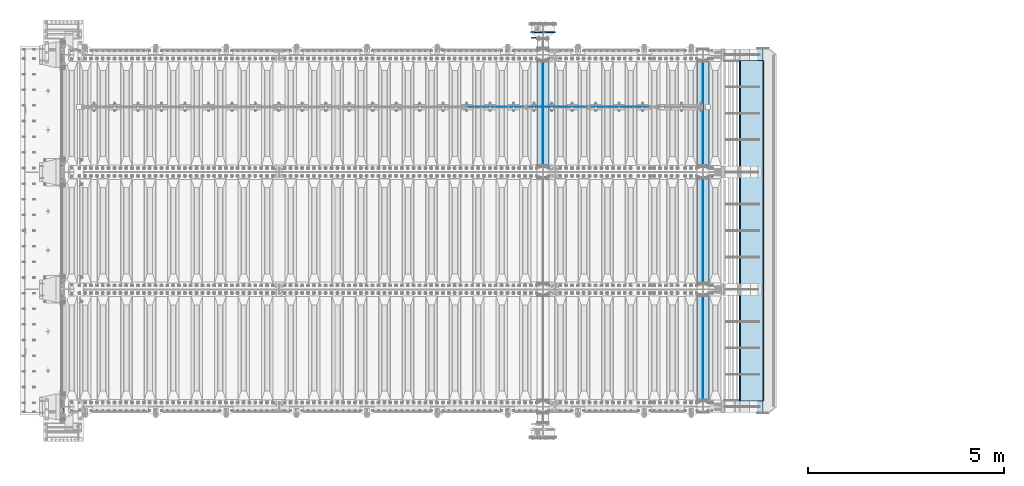
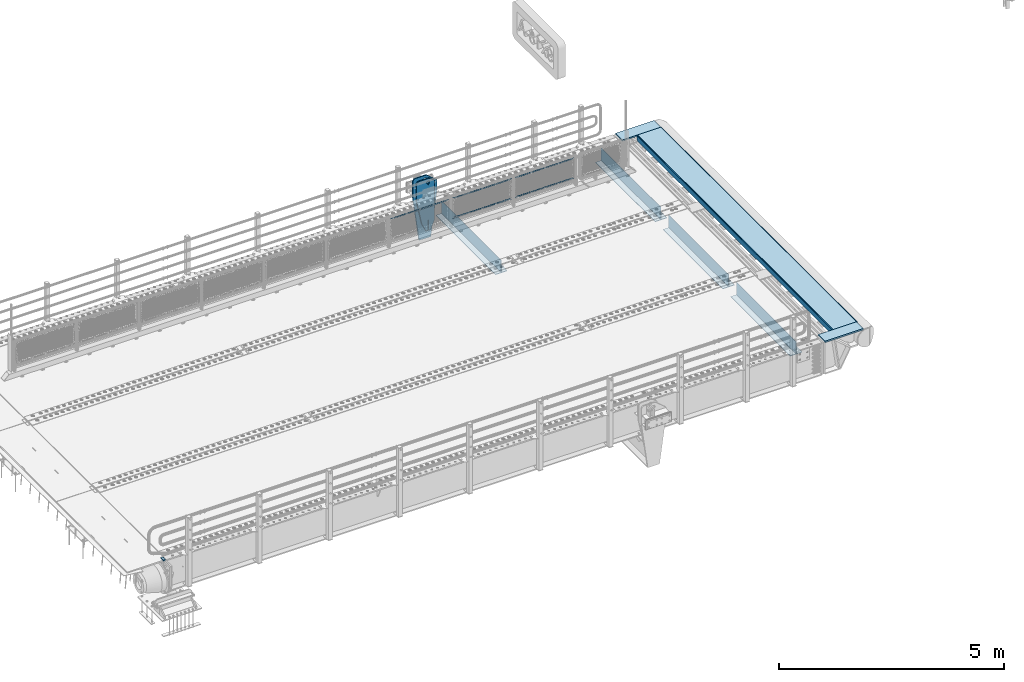
# One storey, part 195 of 247: 20 plates.
"""IFC2X3 building model written with IfcOpenShell, lengths in millimetres."""

import ifcopenshell
import ifcopenshell.guid

model = None  # the IFC model being written
_history = None  # IfcOwnerHistory: only IFC2X3 demands one
_inside = {}  # id of a spatial element -> (the spatial element, [elements in it])
_under = {}  # id of a project, library or spatial element -> (it, [spatial elements below it])
_declared = {}  # id of a project -> (the project, [libraries it declares])
_typed = {}  # id of a type object -> (the type object, [elements of that type])
_made_of = {}  # id of a material, layer set ... -> (it, [elements and type objects made of it])


def new_model(schema):
    """Start an empty IFC model of exactly this schema.

    Asked for "IFC4X3", IfcOpenShell would pick the latest addendum, in which some entities
    have other attributes; the version numbers below select the first issue.
    IFC2X3 requires an IfcOwnerHistory on every rooted entity: one is made here for all.
    """
    global model, _history
    if schema == "IFC4X3":
        model = ifcopenshell.file(schema_version=(4, 3, 0, 0))
    else:
        model = ifcopenshell.file(schema=schema)
    _inside.clear()
    _under.clear()
    _declared.clear()
    _typed.clear()
    _made_of.clear()
    _history = None
    if model.schema == "IFC2X3":
        org = make("IfcOrganization", Name="unknown")
        user = make(
            "IfcPersonAndOrganization",
            ThePerson=make("IfcPerson", FamilyName="unknown"),
            TheOrganization=org,
        )
        app = make(
            "IfcApplication",
            ApplicationDeveloper=org,
            Version="unknown",
            ApplicationFullName="unknown",
            ApplicationIdentifier="unknown",
        )
        _history = make(
            "IfcOwnerHistory",
            OwningUser=user,
            OwningApplication=app,
            ChangeAction="ADDED",
            CreationDate=0,
        )
    return model


def make(cls, **values):
    """One entity of the class cls with the attributes given. An attribute that is None is left unset."""
    return model.create_entity(
        cls, **{name: value for name, value in values.items() if value is not None}
    )


def rooted(cls, **values):
    """An entity with a GlobalId (a new one), such as an element, a storey or a relation."""
    return make(cls, GlobalId=ifcopenshell.guid.new(), OwnerHistory=_history, **values)


def si_unit(unit_type, name, prefix=None):
    """IfcSIUnit, for example si_unit("LENGTHUNIT", "METRE", prefix="MILLI")."""
    return make("IfcSIUnit", UnitType=unit_type, Prefix=prefix, Name=name)


def assignment(units):
    """IfcUnitAssignment: the units of a project."""
    return None if units is None else make("IfcUnitAssignment", Units=units)


def point(xyz):
    """IfcCartesianPoint."""
    return None if xyz is None else make("IfcCartesianPoint", Coordinates=xyz)


def direction(xyz):
    """IfcDirection."""
    return None if xyz is None else make("IfcDirection", DirectionRatios=xyz)


def frame(location, z_axis=None, x_axis=None):
    """IfcAxis2Placement3D, a coordinate frame: its origin and axes. An axis left out is left unset."""
    return make(
        "IfcAxis2Placement3D",
        Location=point(location),
        Axis=direction(z_axis),
        RefDirection=direction(x_axis),
    )


def origin_with_axes():
    """The frame at (0, 0, 0) with the z axis (0, 0, 1) and the x axis (1, 0, 0) written out."""
    return frame((0.0, 0.0, 0.0), z_axis=(0.0, 0.0, 1.0), x_axis=(1.0, 0.0, 0.0))


def place(relative_to, where):
    """IfcLocalPlacement: puts the frame where relative to a parent placement (None: the world)."""
    return make(
        "IfcLocalPlacement", PlacementRelTo=relative_to, RelativePlacement=where
    )


def context(
    kind, dimensions, precision=None, world=None, true_north=None, identifier=None
):
    """IfcGeometricRepresentationContext, for example the 3D "Model" context."""
    return make(
        "IfcGeometricRepresentationContext",
        ContextIdentifier=identifier,
        ContextType=kind,
        CoordinateSpaceDimension=dimensions,
        Precision=precision,
        WorldCoordinateSystem=world,
        TrueNorth=true_north,
    )


def subcontext(parent, identifier, kind, view, scale=None):
    """IfcGeometricRepresentationSubContext, for example "Body" below "Model"."""
    return make(
        "IfcGeometricRepresentationSubContext",
        ContextIdentifier=identifier,
        ContextType=kind,
        ParentContext=parent,
        TargetScale=scale,
        TargetView=view,
    )


def project(units=None, contexts=None):
    """IfcProject with its units and contexts."""
    return rooted(
        "IfcProject",
        Name="project",
        RepresentationContexts=contexts,
        UnitsInContext=assignment(units),
    )


def spatial(cls, under=None, at=None, **own):
    """A site, building, storey or space (cls), placed at a placement, below another one or the project."""
    s = rooted(cls, ObjectPlacement=at, **own)
    if under is not None:
        _under.setdefault(under.id(), (under, []))[1].append(s)
    return s


def faces_of(points, faces, orient=None, outer=None):
    """IfcFace entities. A face is a list of loops; a loop is a list of indices into points, from 0.

    orient and outer hold one flag for each loop. By default every Orientation is true, the
    first loop of a face is its IfcFaceOuterBound and the others are IfcFaceBound.
    """
    made = []
    for i, loops in enumerate(faces):
        bounds = []
        for j, loop in enumerate(loops):
            is_outer = j == 0 if outer is None else outer[i][j]
            bounds.append(
                make(
                    "IfcFaceOuterBound" if is_outer else "IfcFaceBound",
                    Bound=make("IfcPolyLoop", Polygon=[points[k] for k in loop]),
                    Orientation=True if orient is None else orient[i][j],
                )
            )
        made.append(make("IfcFace", Bounds=bounds))
    return made


def faceted_brep(points, faces, orient=None, outer=None, voids=None):
    """IfcFacetedBrep: a solid bounded by flat faces; with voids (closed shells), ...WithVoids."""
    shared = [point(p) for p in points]
    hull = make("IfcClosedShell", CfsFaces=faces_of(shared, faces, orient, outer))
    if voids is None:
        return make("IfcFacetedBrep", Outer=hull)
    return make(
        "IfcFacetedBrepWithVoids",
        Outer=hull,
        Voids=[
            make(cls, CfsFaces=faces_of(shared, fs, o, b)) for cls, fs, o, b in voids
        ],
    )


def shape(context_of_items, identifier, shape_type, items):
    """IfcShapeRepresentation: the items that make up one representation, for example the "Body"."""
    return make(
        "IfcShapeRepresentation",
        ContextOfItems=context_of_items,
        RepresentationIdentifier=identifier,
        RepresentationType=shape_type,
        Items=items,
    )


def material(Name=None, Category=None):
    """IfcMaterial."""
    return make("IfcMaterial", Name=Name, Category=Category)


def made_of(thing, what):
    """Note that an element or type object is made of a material, layer set ...; save() writes the relation."""
    if what is not None:
        _made_of.setdefault(what.id(), (what, []))[1].append(thing)
    return thing


def type_object(cls, material=None, **own):
    """A type object (cls), such as IfcWallType, which elements share."""
    return made_of(rooted(cls, **own), material)


def element(
    cls,
    number,
    at=None,
    inside=None,
    cuts=None,
    type_object=None,
    material=None,
    context=None,
    identifier="Body",
    shape_type=None,
    held_by="IfcProductDefinitionShape",
    body=None,
    shapes=None,
    **own,
):
    """One element of the class cls, such as IfcWall. Its Tag is "e" and its number.

    at: its placement. inside: the storey or other place that contains it. cuts: it is an
    opening in that element (IfcRelVoidsElement). A single representation is given by context,
    identifier, shape_type and body (its items); several are given by shapes. held_by: the class
    of the entity that holds the representations. save() writes the other relations.
    """
    e = rooted(cls, Tag="e%d" % number, ObjectPlacement=at, **own)
    if body is not None:
        shapes = [shape(context, identifier, shape_type, body)]
    if shapes is not None:
        e.Representation = make(held_by, Representations=shapes)
    if inside is not None:
        _inside.setdefault(inside.id(), (inside, []))[1].append(e)
    if cuts is not None:
        rooted(
            "IfcRelVoidsElement", RelatingBuildingElement=cuts, RelatedOpeningElement=e
        )
    if type_object is not None:
        _typed.setdefault(type_object.id(), (type_object, []))[1].append(e)
    return made_of(e, material)


def aggregate(whole, parts):
    """IfcRelAggregates: a whole, such as a stair, and the parts it consists of."""
    return rooted("IfcRelAggregates", RelatingObject=whole, RelatedObjects=parts)


def save(model, path):
    """Write the relations noted so far, then the file.

    IfcRelAggregates (storeys below a building ...), IfcRelContainedInSpatialStructure (elements
    in a storey), IfcRelDefinesByType, IfcRelAssociatesMaterial and IfcRelDeclares: one each for
    every whole, place, type object, material and project.
    """
    for whole, parts in _under.values():
        aggregate(whole, parts)
    for where, things in _inside.values():
        rooted(
            "IfcRelContainedInSpatialStructure",
            RelatedElements=things,
            RelatingStructure=where,
        )
    for kind, things in _typed.values():
        rooted("IfcRelDefinesByType", RelatedObjects=things, RelatingType=kind)
    for what, things in _made_of.values():
        rooted("IfcRelAssociatesMaterial", RelatedObjects=things, RelatingMaterial=what)
    for by, libraries in _declared.values():
        rooted("IfcRelDeclares", RelatingContext=by, RelatedDefinitions=libraries)
    model.write(path)


model = new_model("IFC2X3")

# Units and contexts
model_context = context("Model", 3, precision=1e-05, world=origin_with_axes())
body_context = subcontext(model_context, "Body", "Model", "MODEL_VIEW")
ifc_project = project(units=[si_unit("LENGTHUNIT", "METRE", prefix="MILLI"), si_unit("AREAUNIT", "SQUARE_METRE"), si_unit("VOLUMEUNIT", "CUBIC_METRE"), si_unit("MASSUNIT", "GRAM", prefix="KILO"), si_unit("TIMEUNIT", "SECOND"), si_unit("PLANEANGLEUNIT", "RADIAN"), si_unit("SOLIDANGLEUNIT", "STERADIAN"), si_unit("THERMODYNAMICTEMPERATUREUNIT", "DEGREE_CELSIUS"), si_unit("LUMINOUSINTENSITYUNIT", "LUMEN")], contexts=[model_context])

# Site, building, storey
site_placement = place(None, origin_with_axes())
site = spatial("IfcSite", under=ifc_project, at=site_placement, CompositionType="ELEMENT")
building_placement = place(site_placement, origin_with_axes())
building = spatial("IfcBuilding", under=site, at=building_placement, Name="Standard", CompositionType="ELEMENT")
storey_placement = place(building_placement, origin_with_axes())
storey = spatial("IfcBuildingStorey", under=building, at=storey_placement, Name="Undefined", CompositionType="ELEMENT", Elevation=0.0)

# Plates
ifc_material_1 = material()
plate_type_1 = type_object("IfcPlateType", PredefinedType="NOTDEFINED")
plate_1_placement = place(storey_placement, frame((-10.0000000600431, -89.9999995680746, -15.999780610769), z_axis=(-1.0, 0.0, 0.0), x_axis=(0.0, -4.95099999998473e-06, 0.999999999987744)))
element("IfcPlate", 1, at=plate_1_placement, inside=storey, type_object=plate_type_1, material=ifc_material_1, context=body_context, shape_type="Brep", body=[
    faceted_brep([(0.0, -59.9999999999991, 0.0), (-0.000933120085690575, -60.0, 60.0), (-0.000933120085690575, 60.0, 60.0), (-3.5527136788005e-15, 60.0000000000005, 0.0), (24.9991450303709, -60.0, 60.0), (24.9991450303709, 60.0, 60.0), (26.544215218168, -60.0, 59.7552873850884), (26.544215218168, 60.0, 59.7552873850884), (27.9380461396139, -60.0, 59.0451032459123), (27.9380461396139, 60.0, 59.0451032459123), (29.0442025908961, -60.0, 57.9389639895784), (29.0442025908961, 60.0, 57.9389639895784), (29.7544083969366, -60.0, 56.5451441080361), (29.7544083969366, 60.0, 56.5451441080361), (29.9991450297669, -60.0, 55.0000777244568), (29.9991450297668, 60.0, 55.0000777244568), (29.999922274335, -60.0, 5.00007772445704), (29.999922274335, 60.0, 5.00007772445704), (29.7552240705896, -60.0, 3.45497416452589), (29.7552240705896, 60.0, 3.45497416452589), (29.0450346578116, -60.0, 2.0611114669096), (29.0450346578116, 60.0, 2.06111146690959), (27.9388736885072, -60.0, 0.954933302319514), (27.9388736885072, 60.0, 0.954933302319514), (26.5450220308766, -60.0, 0.244722222183091), (26.5450220308766, 60.0, 0.244722222183089), (24.9999222749392, -60.0, 2.66453525910038e-13), (24.9999222749392, 60.0, 2.66453525910038e-13)], [[[0, 1, 2, 3]], [[1, 4, 5, 2]], [[4, 6, 7, 5]], [[6, 8, 9, 7]], [[8, 10, 11, 9]], [[10, 12, 13, 11]], [[12, 14, 15, 13]], [[14, 16, 17, 15]], [[16, 18, 19, 17]], [[18, 20, 21, 19]], [[20, 22, 23, 21]], [[22, 24, 25, 23]], [[24, 26, 27, 25]], [[26, 0, 3, 27]], [[5, 7, 9, 11, 13, 15, 17, 19, 21, 23, 25, 27, 3, 2]], [[26, 24, 22, 20, 18, 16, 14, 12, 10, 8, 6, 4, 1, 0]]]),
])
ifc_material_2 = material(Name="STEEL/S355N")
plate_type_2 = type_object("IfcPlateType", PredefinedType="NOTDEFINED")
for number, where, z_axis, x_axis in (
    (2, (16195.0, 175.0, -343.0), (0.0, 1.0, 0.0), (1.0, 0.0, 0.0)),
    (3, (16195.0, 3175.0, -343.0), (0.0, 1.0, 0.0), (1.0, 0.0, 0.0)),
    (4, (16195.0, 6175.0, -343.0), (0.0, 1.0, 0.0), (1.0, 0.0, 0.0)),
    (5, (12100.0, 6175.0, -343.0), (0.0, 1.0, 0.0), (1.0, 0.0, 0.0)),
):
    element("IfcPlate", number, at=place(storey_placement, frame(where, z_axis=z_axis, x_axis=x_axis)), inside=storey, type_object=plate_type_2, material=ifc_material_2, context=body_context, shape_type="Brep", body=[
        faceted_brep([(0.0, -7.0, 0.0), (0.0, -7.0, 2650.0), (0.0, 7.0, 2650.0), (0.0, 7.0, 0.0), (300.0, -7.0, 2650.0), (300.0, 7.0, 2650.0), (300.0, -7.0, 0.0), (300.0, 7.0, 0.0)], [[[0, 1, 2, 3]], [[1, 4, 5, 2]], [[4, 6, 7, 5]], [[6, 0, 3, 7]], [[5, 7, 3, 2]], [[6, 4, 1, 0]]]),
    ])
plate_type_3 = type_object("IfcPlateType", PredefinedType="NOTDEFINED")
for number, where, z_axis, x_axis in (
    (6, (16345.0, 2825.0, 0.0), (0.0, 0.0, -1.0), (0.0, -0.999999999999548, -9.5100000000016e-07)),
    (7, (16345.0, 5825.0, 0.0), (0.0, 0.0, -1.0), (0.0, -0.999999999999548, -9.5100000000016e-07)),
    (8, (16345.0, 8825.0, 0.0), (0.0, 0.0, -1.0), (0.0, -0.999999999999548, -9.5100000000016e-07)),
    (9, (12250.0, 8825.0, 0.0), (0.0, 0.0, -1.0), (0.0, -0.999999999999548, -9.5100000000016e-07)),
):
    element("IfcPlate", number, at=place(storey_placement, frame(where, z_axis=z_axis, x_axis=x_axis)), inside=storey, type_object=plate_type_3, material=ifc_material_2, context=body_context, shape_type="Brep", body=[
        faceted_brep([(9.04219632502645e-09, -5.00000000143385, -2.89173840428703e-09), (0.0, -5.0, 336.0), (0.0, 5.0, 336.0), (7.66340235713869e-09, 4.99999999856618, -2.89173840428703e-09), (2650.0, -5.0, 336.0), (2650.0, 5.0, 336.0), (2650.0, -5.0, 0.0), (2650.0, 5.0, 0.0)], [[[0, 1, 2, 3]], [[1, 4, 5, 2]], [[4, 6, 7, 5]], [[6, 0, 3, 7]], [[5, 7, 3, 2]], [[6, 4, 1, 0]]]),
    ])
ifc_material_3 = material(Name="Misc_Undefined")
plate_type_4 = type_object("IfcPlateType", PredefinedType="NOTDEFINED")
plate_2_placement = place(storey_placement, frame((13474.5050117304, 7670.5, 351.520303374641), z_axis=(0.0, 0.0, 1.0), x_axis=(1.0, 0.0, 0.0)))
element("IfcPlate", 10, at=plate_2_placement, inside=storey, type_object=plate_type_4, material=ifc_material_3, context=body_context, shape_type="Brep", body=[
    faceted_brep([(1.81898940354586e-12, -1.5, -5.6843418860808e-14), (35.0002975463885, -1.5, 34.9996948242187), (35.0002975463885, 1.5, 34.9996948242187), (1.81898940354586e-12, 1.5, -5.6843418860808e-14), (1457.99035644531, -1.5, 34.9999923706055), (1457.99035644531, 1.5, 34.9999923706055), (1492.98999023438, -1.5, -2.87985812974512e-09), (1492.98999023438, 1.5, -2.87985812974512e-09)], [[[0, 1, 2, 3]], [[1, 4, 5, 2]], [[4, 6, 7, 5]], [[6, 0, 3, 7]], [[5, 7, 3, 2]], [[6, 4, 1, 0]]]),
])
plate_3_placement = place(storey_placement, frame((14967.5000001876, 7670.5, 914.520000175701), z_axis=(-0.707103624179499, 0.0, 0.707109938179501), x_axis=(-0.707109938179502, 0.0, -0.707103624179498)))
element("IfcPlate", 11, at=plate_3_placement, inside=storey, type_object=plate_type_4, material=ifc_material_3, context=body_context, shape_type="Brep", body=[
    faceted_brep([(1.81898940354586e-12, -1.5, -5.6843418860808e-14), (1055.71520996094, -1.5, 1055.70581054688), (1055.71520996094, 1.5, 1055.70581054688), (1.81898940354586e-12, 1.5, -5.6843418860808e-14), (1055.70812988281, -1.5, 1006.20135498047), (1055.70812988281, 1.5, 1006.20135498047), (49.4976959228497, -1.5, 7.09405867382884e-11), (49.4976959228497, 1.5, 7.09405867382884e-11)], [[[0, 1, 2, 3]], [[1, 4, 5, 2]], [[4, 6, 7, 5]], [[6, 0, 3, 7]], [[5, 7, 3, 2]], [[6, 4, 1, 0]]]),
])
plate_4_placement = place(storey_placement, frame((11874.5050117304, 7670.5, 351.520303374641), z_axis=(0.0, 0.0, 1.0), x_axis=(1.0, 0.0, 0.0)))
element("IfcPlate", 12, at=plate_4_placement, inside=storey, type_object=plate_type_4, material=ifc_material_3, context=body_context, shape_type="Brep", body=[
    faceted_brep([(1.81898940354586e-12, -1.5, -5.6843418860808e-14), (35.0002975463885, -1.5, 34.9996948242187), (35.0002975463885, 1.5, 34.9996948242187), (1.81898940354586e-12, 1.5, -5.6843418860808e-14), (1457.99035644531, -1.5, 34.9999923706055), (1457.99035644531, 1.5, 34.9999923706055), (1492.98999023438, -1.5, -2.87985812974512e-09), (1492.98999023438, 1.5, -2.87985812974512e-09)], [[[0, 1, 2, 3]], [[1, 4, 5, 2]], [[4, 6, 7, 5]], [[6, 0, 3, 7]], [[5, 7, 3, 2]], [[6, 4, 1, 0]]]),
])
for number, where, z_axis, x_axis in (
    (13, (13367.5000001876, 7670.5, 914.520000175701), (-0.707103624179499, 0.0, 0.707109938179501), (-0.707109938179502, 0.0, -0.707103624179498)),
    (14, (11767.5000001876, 7670.5, 914.520000175701), (-0.707103624179499, 0.0, 0.707109938179501), (-0.707109938179502, 0.0, -0.707103624179498)),
):
    element("IfcPlate", number, at=place(storey_placement, frame(where, z_axis=z_axis, x_axis=x_axis)), inside=storey, type_object=plate_type_4, material=ifc_material_3, context=body_context, shape_type="Brep", body=[
        faceted_brep([(1.81898940354586e-12, -1.5, -5.6843418860808e-14), (1055.71520996094, -1.5, 1055.70581054688), (1055.71520996094, 1.5, 1055.70581054688), (1.81898940354586e-12, 1.5, -5.6843418860808e-14), (1055.70812988281, -1.5, 1006.20135498047), (1055.70812988281, 1.5, 1006.20135498047), (49.4976959228497, -1.5, 7.09405867382884e-11), (49.4976959228497, 1.5, 7.09405867382884e-11)], [[[0, 1, 2, 3]], [[1, 4, 5, 2]], [[4, 6, 7, 5]], [[6, 0, 3, 7]], [[5, 7, 3, 2]], [[6, 4, 1, 0]]]),
    ])
plate_type_5 = type_object("IfcPlateType", PredefinedType="NOTDEFINED")
for number, where, z_axis, x_axis in (
    (15, (16896.9988298906, 150.0, -10.0000000000094), (1.0, 0.0, 0.0), (0.0, -0.999999999999548, -9.5100000000016e-07)),
    (16, (16896.9988298905, 9150.0, -10.0000000004865), (1.0, 0.0, 0.0), (0.0, -0.999999999999548, -9.5100000000016e-07)),
):
    element("IfcPlate", number, at=place(storey_placement, frame(where, z_axis=z_axis, x_axis=x_axis)), inside=storey, type_object=plate_type_5, material=ifc_material_2, context=body_context, shape_type="Brep", body=[
        faceted_brep([(300.0, 7.0, 986.0), (300.0, 20.0, 956.0), (-3.35091954184463e-11, 20.0, 956.0), (-3.45607986673713e-11, 7.0, 986.0), (0.0, 20.0, 0.0), (0.0, -20.0, 0.0), (-3.45607986673713e-11, -20.0, 986.0), (300.0, -20.0, 986.0), (300.0, -20.0, -1.81898940354586e-12), (300.0, 20.0, -1.81898940354586e-12)], [[[0, 1, 2, 3]], [[4, 5, 6, 3, 2]], [[6, 7, 0, 3]], [[7, 8, 9, 1, 0]], [[8, 5, 4, 9]], [[9, 4, 2, 1]], [[8, 7, 6, 5]]]),
    ])
plate_type_6 = type_object("IfcPlateType", PredefinedType="NOTDEFINED")
plate_5_placement = place(storey_placement, frame((12409.9999999856, 9440.00000001511, -945.000018222004), z_axis=(-0.901283188008788, 0.0, 0.433230441004225), x_axis=(-0.433230441004223, 0.0, -0.901283188008789)))
element("IfcPlate", 17, at=plate_5_placement, inside=storey, type_object=plate_type_6, material=ifc_material_2, context=body_context, shape_type="Brep", body=[
    faceted_brep([(-929.368911797765, -14.9999999999964, 583.252555031771), (-929.368911797765, 15.0000000000036, 583.252555031771), (-937.308302015212, 15.0000000000036, 596.689503306548), (-937.308302015212, -14.9999999999964, 596.689503306548), (-939.501244651428, 15.0000000000036, 612.141897896323), (-939.501244651428, -14.9999999999964, 612.141897896323), (-935.613884069125, 15.0000000000036, 627.257251801113), (-935.613884069125, -14.9999999999964, 627.257251801113), (-926.238035677946, 15.0000000000036, 639.734389409936), (-926.238035677946, -14.9999999999964, 639.734389409936), (-912.801087403171, 15.0000000000036, 647.673779627383), (-912.801087403171, -14.9999999999964, 647.673779627383), (-897.348692813394, 15.0000000000036, 649.866722263598), (-897.348692813394, -14.9999999999964, 649.866722263598), (-882.233338908604, 15.0000000000036, 645.979361681295), (-882.233338908604, -14.9999999999964, 645.979361681295), (-869.756201299781, 15.0000000000036, 636.603513290116), (-869.756201299781, -14.9999999999964, 636.603513290116), (-861.816811082334, 15.0000000000036, 623.166565015341), (-861.816811082334, -14.9999999999964, 623.166565015341), (-859.623868446118, 15.0000000000036, 607.714170425565), (-859.623868446118, -14.9999999999964, 607.714170425565), (-863.511229028422, 15.0000000000036, 592.598816520775), (-863.511229028422, -14.9999999999964, 592.598816520775), (-872.8870774196, 15.0000000000036, 580.121678911952), (-872.8870774196, -14.9999999999964, 580.121678911952), (-886.324025694375, 15.0000000000036, 572.182288694507), (-886.324025694375, -14.9999999999964, 572.182288694507), (-901.776420284152, 15.0000000000036, 569.98934605829), (-901.776420284152, -14.9999999999964, 569.98934605829), (-916.891774188942, 15.0000000000036, 573.876706640593), (-916.891774188942, -14.9999999999964, 573.876706640593), (264.349945986183, -15.0, 42.1349880418893), (264.349945986183, 15.0, 42.1349880418893), (15.5957837368442, 15.0000000000036, 161.706590892942), (15.5957837368442, -14.9999999999964, 161.706590892942), (244.096420288085, -15.0, -6.73026079311967e-11), (244.096420288085, 15.0, -6.73026079311967e-11), (0.0, -15.0, 0.0), (0.0, 15.0, 0.0), (-976.801696777345, -15.0, 469.530822753904), (-976.801696777345, 15.0, 469.530822753904), (-1005.61097945758, -15.0, 584.572341407271), (-1005.61097945758, 15.0, 584.572341407271), (-1008.62086606962, -15.0, 603.379087420497), (-1008.62086606962, 15.0, 603.379087420497), (-1008.34154488138, -15.0, 622.42311778954), (-1008.34154488138, 15.0, 622.42311778954), (-1004.7813898293, -15.0, 641.133500175492), (-1004.7813898293, 15.0, 641.133500175492), (-998.047132923921, -15.0, 658.949304871174), (-998.047132923921, 15.0, 658.949304871174), (-903.392995239108, -15.0, 855.865677422371), (-903.392995239108, 15.0, 855.865677422371), (-891.965893301475, -15.0, 873.346258360978), (-891.965893301475, 15.0, 873.346258360978), (-876.403853384473, -15.0, 887.273651594), (-876.403853384473, 15.0, 887.273651594), (-857.767402657617, -15.0, 896.698728408073), (-857.767402657617, 15.0, 896.698728408073), (-837.326584280018, -15.0, 900.979185474776), (-837.326584280018, 15.0, 900.979185474776), (-816.474406068869, -15.0, 899.823316755486), (-816.474406068869, 15.0, 899.823316755486), (-796.631909330703, -15.0, 893.309892783485), (-796.631909330703, 15.0, 893.309892783485), (-427.105804443359, -15.0, 715.685424804688), (-427.105804443359, 15.0, 715.685424804688), (138.633743286132, -15.0, 288.41061401367), (138.633743286132, 15.0, 288.41061401367), (291.101928710937, -15.0, 97.7892227172833), (291.101928710937, 15.0, 97.7892227172833), (270.848403398947, -15.0, 55.6542354785815), (270.848403398947, 15.0, 55.6542354785815), (22.0942403519075, -14.9999999999964, 175.225838713073), (22.0942403519075, 15.0000000000036, 175.225838713073), (-855.850321911345, -15.0, 588.916357789718), (-852.143242453128, -15.0, 592.234043561486), (-847.175983322761, -15.0, 591.958700645248), (-843.858297550992, -15.0, 588.25162118703), (-844.133640467231, -15.0, 583.284362056664), (-847.840719925449, -15.0, 579.966676284894), (-852.807979055816, -15.0, 580.242019201134), (-856.125664827585, -15.0, 583.94909865935), (-844.133640467231, 15.0, 583.284362056664), (-847.840719925449, 15.0, 579.966676284894), (-843.858297550992, 15.0, 588.25162118703), (-847.175983322761, 15.0, 591.958700645248), (-852.143242453128, 15.0, 592.234043561486), (-855.850321911345, 15.0, 588.916357789718), (-856.125664827585, 15.0, 583.94909865935), (-852.807979055816, 15.0, 580.242019201134)], [[[0, 1, 2, 3]], [[3, 2, 4, 5]], [[5, 4, 6, 7]], [[7, 6, 8, 9]], [[9, 8, 10, 11]], [[11, 10, 12, 13]], [[13, 12, 14, 15]], [[15, 14, 16, 17]], [[17, 16, 18, 19]], [[19, 18, 20, 21]], [[21, 20, 22, 23]], [[23, 22, 24, 25]], [[25, 24, 26, 27]], [[27, 26, 28, 29]], [[29, 28, 30, 31]], [[31, 30, 1, 0]], [[32, 33, 34, 35]], [[36, 37, 33, 32]], [[36, 38, 39, 37]], [[38, 40, 41, 39]], [[40, 42, 43, 41]], [[42, 44, 45, 43]], [[44, 46, 47, 45]], [[46, 48, 49, 47]], [[48, 50, 51, 49]], [[50, 52, 53, 51]], [[52, 54, 55, 53]], [[54, 56, 57, 55]], [[56, 58, 59, 57]], [[58, 60, 61, 59]], [[60, 62, 63, 61]], [[62, 64, 65, 63]], [[64, 66, 67, 65]], [[66, 68, 69, 67]], [[68, 70, 71, 69]], [[71, 70, 72, 73]], [[74, 75, 73, 72]], [[35, 34, 75, 74]], [[72, 70, 68, 66, 64, 62, 60, 58, 56, 54, 52, 50, 48, 46, 44, 42, 40, 38, 36, 32, 35, 74], [3, 5, 7, 9, 11, 13, 15, 17, 19, 21, 23, 25, 27, 29, 31, 0], [76, 77, 78, 79, 80, 81, 82, 83]], [[80, 84, 85, 81]], [[79, 86, 84, 80]], [[78, 87, 86, 79]], [[77, 88, 87, 78]], [[76, 89, 88, 77]], [[83, 90, 89, 76]], [[82, 91, 90, 83]], [[81, 85, 91, 82]], [[37, 39, 41, 43, 45, 47, 49, 51, 53, 55, 57, 59, 61, 63, 65, 67, 69, 71, 73, 75, 34, 33], [26, 24, 22, 20, 18, 16, 14, 12, 10, 8, 6, 4, 2, 1, 30, 28], [84, 86, 87, 88, 89, 90, 91, 85]]]),
])
plate_type_7 = type_object("IfcPlateType", PredefinedType="NOTDEFINED")
plate_6_placement = place(storey_placement, frame((12399.9999999856, 9580.00000001511, -1470.000018222), z_axis=(0.0, 0.0, 1.0), x_axis=(-1.0, 0.0, 0.0)))
element("IfcPlate", 18, at=plate_6_placement, inside=storey, type_object=plate_type_7, material=ifc_material_2, context=body_context, shape_type="Brep", body=[
    faceted_brep([(145.403805922693, -14.9999999999999, 1549.59619407771), (145.403805922693, 15.0, 1549.59619407771), (150.000000000406, 15.0, 1551.5), (150.000000000406, -14.9999999999999, 1551.5), (154.596194078118, 15.0, 1549.59619407771), (154.596194078118, -14.9999999999999, 1549.59619407771), (156.500000000406, 15.0, 1545.0), (156.500000000406, -14.9999999999999, 1545.0), (154.596194078118, 15.0, 1540.40380592229), (154.596194078118, -14.9999999999999, 1540.40380592229), (150.000000000406, 15.0, 1538.5), (150.000000000406, -14.9999999999999, 1538.5), (145.403805922693, 15.0, 1540.40380592229), (145.403805922693, -14.9999999999999, 1540.40380592229), (143.500000000406, 15.0, 1545.0), (143.500000000406, -14.9999999999999, 1545.0), (300.0, -15.0, 0.0), (0.0, -15.0, 0.0), (0.0, 15.0, 0.0), (300.0, 15.0, 0.0), (462.5, -15.0, 1210.0), (462.5, 15.0, 1210.0), (462.5, -15.0, 1630.0), (462.5, 15.0, 1630.0), (459.774066103126, -15.0, 1650.7055236082), (459.774066103126, 15.0, 1650.7055236082), (451.782032302755, -15.0, 1670.0), (451.782032302755, 15.0, 1670.0), (439.068542494924, -15.0, 1686.56854249492), (439.068542494924, 15.0, 1686.56854249492), (422.5, -15.0, 1699.28203230276), (422.5, 15.0, 1699.28203230276), (403.205523608201, -15.0, 1707.27406610313), (403.205523608201, 15.0, 1707.27406610313), (382.5, -15.0, 1710.0), (382.5, 15.0, 1710.0), (151.788081037079, -15.0, 1710.0), (151.788081037079, 15.0, 1710.0), (132.694887325031, -15.0, 1708.33028179541), (132.694887325031, 15.0, 1708.33028179541), (114.181334578885, -15.0, 1703.37181734316), (114.181334578885, 15.0, 1703.37181734316), (96.8094667268542, -15.0, 1695.27513824985), (96.8094667268542, 15.0, 1695.27513824985), (81.1066678416755, -15.0, 1684.28604765144), (81.1066678416755, 15.0, 1684.28604765144), (-162.5, -15.0, 1480.0), (-162.5, 15.0, 1480.0), (-162.5, -15.0, 1210.0), (-162.5, 15.0, 1210.0), (121.715728752944, -15.0, 1628.28427124746), (134.692662705802, -15.0, 1636.95518130045), (150.000000000406, -15.0, 1640.0), (165.307337295009, -15.0, 1636.95518130045), (178.284271247867, -15.0, 1628.28427124746), (186.955181300857, -15.0, 1615.3073372946), (190.000000000406, -15.0, 1600.0), (186.955181300857, -15.0, 1584.6926627054), (178.284271247867, -15.0, 1571.71572875254), (165.307337295009, -15.0, 1563.04481869955), (150.000000000406, -15.0, 1560.0), (134.692662705802, -15.0, 1563.04481869955), (121.715728752944, -15.0, 1571.71572875254), (113.044818699955, -15.0, 1584.6926627054), (110.000000000406, -15.0, 1600.0), (113.044818699955, -15.0, 1615.3073372946), (121.715728752944, 14.999999999953, 1571.71572875254), (113.044818699955, 14.999999999953, 1584.6926627054), (134.692662705802, 14.999999999953, 1563.04481869955), (150.000000000406, 14.999999999953, 1560.0), (165.307337295009, 14.999999999953, 1563.04481869955), (178.284271247867, 14.999999999953, 1571.71572875254), (186.955181300857, 14.999999999953, 1584.6926627054), (190.000000000406, 14.999999999953, 1600.0), (186.955181300857, 14.999999999953, 1615.3073372946), (178.284271247867, 14.999999999953, 1628.28427124746), (165.307337295009, 14.999999999953, 1636.95518130045), (150.000000000406, 14.999999999953, 1640.0), (134.692662705802, 14.999999999953, 1636.95518130045), (121.715728752944, 14.999999999953, 1628.28427124746), (113.044818699955, 14.999999999953, 1615.3073372946), (110.000000000406, 14.999999999953, 1600.0)], [[[0, 1, 2, 3]], [[3, 2, 4, 5]], [[5, 4, 6, 7]], [[7, 6, 8, 9]], [[9, 8, 10, 11]], [[11, 10, 12, 13]], [[13, 12, 14, 15]], [[15, 14, 1, 0]], [[16, 17, 18, 19]], [[20, 16, 19, 21]], [[22, 20, 21, 23]], [[24, 22, 23, 25]], [[26, 24, 25, 27]], [[28, 26, 27, 29]], [[30, 28, 29, 31]], [[32, 30, 31, 33]], [[34, 32, 33, 35]], [[36, 34, 35, 37]], [[38, 36, 37, 39]], [[40, 38, 39, 41]], [[42, 40, 41, 43]], [[44, 42, 43, 45]], [[46, 44, 45, 47]], [[48, 46, 47, 49]], [[17, 48, 49, 18]], [[16, 20, 22, 24, 26, 28, 30, 32, 34, 36, 38, 40, 42, 44, 46, 48, 17], [3, 5, 7, 9, 11, 13, 15, 0], [50, 51, 52, 53, 54, 55, 56, 57, 58, 59, 60, 61, 62, 63, 64, 65]], [[62, 66, 67, 63]], [[61, 68, 66, 62]], [[60, 69, 68, 61]], [[59, 70, 69, 60]], [[58, 71, 70, 59]], [[57, 72, 71, 58]], [[56, 73, 72, 57]], [[55, 74, 73, 56]], [[54, 75, 74, 55]], [[53, 76, 75, 54]], [[52, 77, 76, 53]], [[51, 78, 77, 52]], [[50, 79, 78, 51]], [[65, 80, 79, 50]], [[64, 81, 80, 65]], [[63, 67, 81, 64]], [[47, 45, 43, 41, 39, 37, 35, 33, 31, 29, 27, 25, 23, 21, 19, 18, 49], [10, 8, 6, 4, 2, 1, 14, 12], [66, 68, 69, 70, 71, 72, 73, 74, 75, 76, 77, 78, 79, 80, 81, 67]]]),
])
plate_type_8 = type_object("IfcPlateType", PredefinedType="NOTDEFINED")
plate_7_placement = place(storey_placement, frame((17290.5545510642, 8850.00000000159, -155.274111776634), z_axis=(0.0, -0.999999999999548, -9.5100000000016e-07), x_axis=(-0.0871556999853744, 0.0, 0.99619470183296)))
element("IfcPlate", 19, at=plate_7_placement, inside=storey, type_object=plate_type_8, material=ifc_material_2, context=body_context, shape_type="Brep", body=[
    faceted_brep([(-5.6843418860808e-14, -9.99999999999989, 3.5527136788005e-15), (0.0, -9.99999999999636, 8700.0), (-2.27373675443232e-13, 10.0, 8700.0), (-5.6843418860808e-14, 10.0000000000001, 3.5527136788005e-15), (155.0, -10.0, 8700.0), (155.0, 10.0, 8700.0), (155.0, -10.0, 0.0), (155.0, 10.0, 0.0)], [[[0, 1, 2, 3]], [[1, 4, 5, 2]], [[4, 6, 7, 5]], [[6, 0, 3, 7]], [[5, 7, 3, 2]], [[6, 4, 1, 0]]]),
])
plate_type_9 = type_object("IfcPlateType", PredefinedType="NOTDEFINED")
plate_8_placement = place(storey_placement, frame((17287.002968026, 8850.00000000156, 0.00398537333359705), z_axis=(0.999999999980065, 4.25000000169061e-07, -6.29999999987441e-06), x_axis=(4.09999996770818e-08, -0.999999999999996, 7.79999999985596e-08)))
element("IfcPlate", 20, at=plate_8_placement, inside=storey, type_object=plate_type_9, material=ifc_material_2, context=body_context, shape_type="Brep", body=[
    faceted_brep([(8700.0, -10.0, 596.995666503903), (8700.0, -5.4957427497726e-13, 616.995666503906), (6.7275379478815e-05, -5.49046919040563e-13, 616.995788574219), (6.50946421956178e-05, -10.0, 596.995788574219), (6.72753812978044e-05, 10.0, 616.995788574219), (-5.6843418860808e-14, 10.0000000000001, 3.5527136788005e-15), (-5.6843418860808e-14, -9.99999999999989, 3.5527136788005e-15), (8700.0, 10.0, 616.995666503906), (8700.0, -10.0, -3.28145688399673e-09), (8700.0, 10.0, -3.27781890518963e-09)], [[[0, 1, 2, 3]], [[4, 5, 6, 3, 2]], [[7, 4, 2, 1]], [[8, 9, 7, 1, 0]], [[8, 6, 5, 9]], [[7, 9, 5, 4]], [[6, 8, 0, 3]]]),
])

save(model, "model.ifc")
